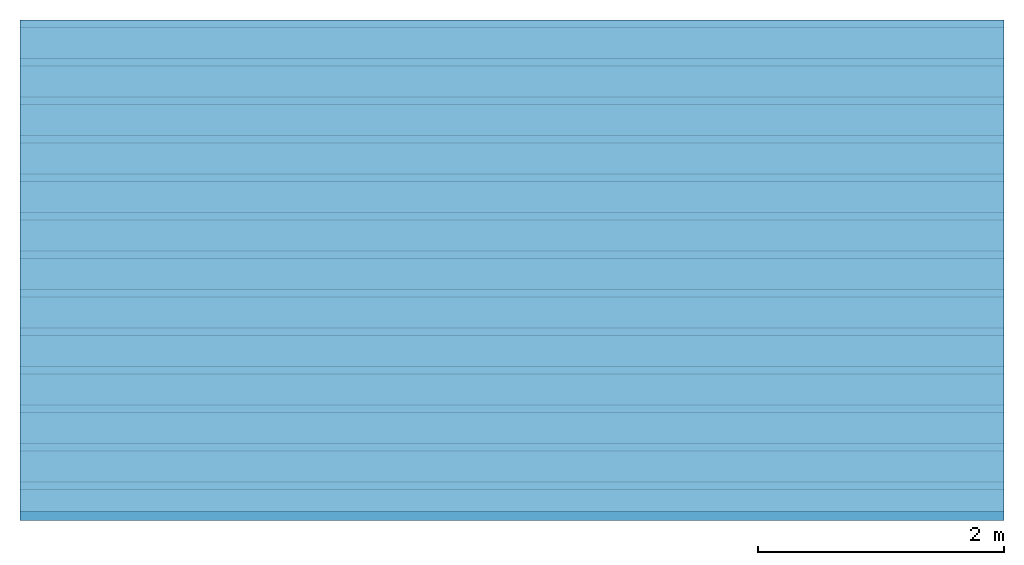
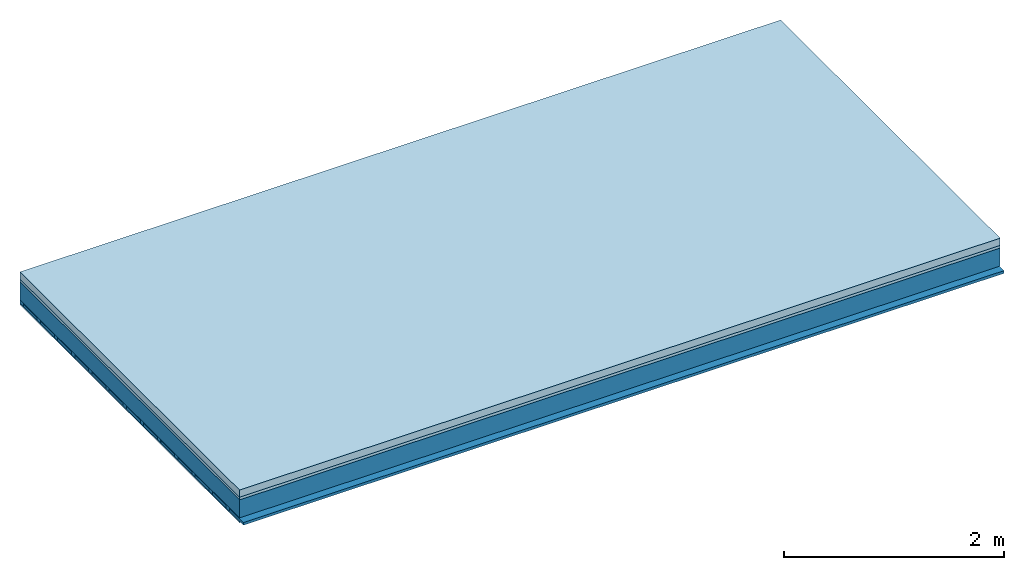
# One storey: 3 members, 3 plates, 1 element without a shape of its own.
"""IFC4 building model written with IfcOpenShell, lengths in metres."""

from ifc_helpers import new_model, si_unit, derived_unit, direction, frame, frame_2d, origin, origin_with_axes, place, context, project, spatial, rectangle, extrude, material, layer, layer_set, type_object, element, aggregate, save


model = new_model("IFC4")

# Units and contexts
plan_context = context("Plan", 3, precision=1e-05, world=origin(), true_north=direction((0.0, 1.0)))
model_context = context("Model", 3, precision=1e-05, world=origin(), true_north=direction((0.0, 1.0)))
ifc_project = project(units=[si_unit("LENGTHUNIT", "METRE"), derived_unit("SOUNDPRESSUREUNIT", [(si_unit("PRESSUREUNIT", "PASCAL", prefix="MICRO"), 0)]), si_unit("ENERGYUNIT", "JOULE", prefix="MEGA"), si_unit("MASSUNIT", "GRAM", prefix="KILO"), derived_unit("THERMALTRANSMITTANCEUNIT", [(si_unit("POWERUNIT", "WATT"), 1), (si_unit("AREAUNIT", "SQUARE_METRE"), -1), (si_unit("THERMODYNAMICTEMPERATUREUNIT", "KELVIN"), -1)]), derived_unit("AREADENSITYUNIT", [(si_unit("MASSUNIT", "GRAM", prefix="KILO"), 1), (si_unit("AREAUNIT", "SQUARE_METRE"), -1)]), derived_unit("USERDEFINED", [(si_unit("ENERGYUNIT", "JOULE", prefix="MEGA"), 1), (si_unit("AREAUNIT", "SQUARE_METRE"), -1)])], contexts=[plan_context, model_context])

# Site, building, storey
site = spatial("IfcSite", under=ifc_project)
building_placement = place(None, origin())
building = spatial("IfcBuilding", under=site, at=building_placement)
storey_placement = place(building_placement, origin())
storey = spatial("IfcBuildingStorey", under=building, at=storey_placement)

# Slab, members, plates
ifc_material_1 = material(Name="Cement screed", Category="04.006")
ifc_layer_1 = layer(ifc_material_1, 0.08, Name="On-material")
ifc_material_2 = material()
ifc_layer_2 = layer(ifc_material_2, 0.03, Name="Impact sound insulation")
ifc_layer_3 = layer(None, 0.2, Name="Supporting structure")
ifc_material_3 = material(Name="of the art")
ifc_layer_4 = layer(ifc_material_3, 0.0, Name="Bond")
ifc_layer_5 = layer(None, 0.04, Name="Battens / profiles")
ifc_material_4 = material(Category="03.007")
ifc_layer_6 = layer(ifc_material_4, 0.015, Name="Ceiling covering 1st layer")
ifc_material_5 = material(Name="Glued joints")
ifc_layer_7 = layer(ifc_material_5, 0.0, Name="Surface / treatment")
ifc_layer_set = layer_set([ifc_layer_1, ifc_layer_2, ifc_layer_3, ifc_layer_4, ifc_layer_5, ifc_layer_6, ifc_layer_7])
slab_type = type_object("IfcSlabType", Name="A0847", PredefinedType="NOTDEFINED", material=ifc_layer_set)
slab_placement = place(None, frame((0.0, 0.0, 0.0), z_axis=(0.0, 0.0, -1.0), x_axis=(1.0, 0.0, 0.0)))
slab = element("IfcSlab", 1, at=slab_placement, inside=storey, type_object=slab_type, material=ifc_layer_set, Name="Slab #1")
ifc_material_6 = material()
member_1_placement = place(slab_placement, origin())
member_1 = element("IfcMember", 2, at=member_1_placement, material=ifc_material_6, Name="Supporting structure", context=plan_context, shape_type="SweptSolid", body=[
    extrude(rectangle(XDim=1.0, YDim=0.2, at=frame_2d((0.5, 0.1), x_axis=(1.0, 0.0))), frame((0.0, 4.0, 0.11), z_axis=(0.0, -1.0, 0.0), x_axis=(1.0, 0.0, 0.0)), (0.0, 0.0, 1.0), 4.0),
    extrude(rectangle(XDim=1.0, YDim=0.2, at=frame_2d((0.5, 0.1), x_axis=(1.0, 0.0))), frame((1.0, 4.0, 0.11), z_axis=(0.0, -1.0, 0.0), x_axis=(1.0, 0.0, 0.0)), (0.0, 0.0, 1.0), 4.0),
    extrude(rectangle(XDim=1.0, YDim=0.2, at=frame_2d((0.5, 0.1), x_axis=(1.0, 0.0))), frame((2.0, 4.0, 0.11), z_axis=(0.0, -1.0, 0.0), x_axis=(1.0, 0.0, 0.0)), (0.0, 0.0, 1.0), 4.0),
    extrude(rectangle(XDim=1.0, YDim=0.2, at=frame_2d((0.5, 0.1), x_axis=(1.0, 0.0))), frame((3.0, 4.0, 0.11), z_axis=(0.0, -1.0, 0.0), x_axis=(1.0, 0.0, 0.0)), (0.0, 0.0, 1.0), 4.0),
    extrude(rectangle(XDim=1.0, YDim=0.2, at=frame_2d((0.5, 0.1), x_axis=(1.0, 0.0))), frame((4.0, 4.0, 0.11), z_axis=(0.0, -1.0, 0.0), x_axis=(1.0, 0.0, 0.0)), (0.0, 0.0, 1.0), 4.0),
    extrude(rectangle(XDim=1.0, YDim=0.2, at=frame_2d((0.5, 0.1), x_axis=(1.0, 0.0))), frame((5.0, 4.0, 0.11), z_axis=(0.0, -1.0, 0.0), x_axis=(1.0, 0.0, 0.0)), (0.0, 0.0, 1.0), 4.0),
    extrude(rectangle(XDim=1.0, YDim=0.2, at=frame_2d((0.5, 0.1), x_axis=(1.0, 0.0))), frame((6.0, 4.0, 0.11), z_axis=(0.0, -1.0, 0.0), x_axis=(1.0, 0.0, 0.0)), (0.0, 0.0, 1.0), 4.0),
    extrude(rectangle(XDim=1.0, YDim=0.2, at=frame_2d((0.5, 0.1), x_axis=(1.0, 0.0))), frame((7.0, 4.0, 0.11), z_axis=(0.0, -1.0, 0.0), x_axis=(1.0, 0.0, 0.0)), (0.0, 0.0, 1.0), 4.0),
])
ifc_material_7 = material()
member_2_placement = place(slab_placement, origin())
member_2 = element("IfcMember", 3, at=member_2_placement, material=ifc_material_7, Name="Battens / profiles", context=plan_context, shape_type="SweptSolid", body=[
    extrude(rectangle(XDim=0.06, YDim=0.04, at=frame_2d((0.03, 0.02), x_axis=(1.0, 0.0))), frame((0.0, 0.0, 0.31), z_axis=(1.0, 0.0, 0.0), x_axis=(0.0, 1.0, 0.0)), (0.0, 0.0, 1.0), 8.0),
    extrude(rectangle(XDim=0.06, YDim=0.04, at=frame_2d((0.03, 0.02), x_axis=(1.0, 0.0))), frame((0.0, 0.313, 0.31), z_axis=(1.0, 0.0, 0.0), x_axis=(0.0, 1.0, 0.0)), (0.0, 0.0, 1.0), 8.0),
    extrude(rectangle(XDim=0.06, YDim=0.04, at=frame_2d((0.03, 0.02), x_axis=(1.0, 0.0))), frame((0.0, 0.626, 0.31), z_axis=(1.0, 0.0, 0.0), x_axis=(0.0, 1.0, 0.0)), (0.0, 0.0, 1.0), 8.0),
    extrude(rectangle(XDim=0.06, YDim=0.04, at=frame_2d((0.03, 0.02), x_axis=(1.0, 0.0))), frame((0.0, 0.939, 0.31), z_axis=(1.0, 0.0, 0.0), x_axis=(0.0, 1.0, 0.0)), (0.0, 0.0, 1.0), 8.0),
    extrude(rectangle(XDim=0.06, YDim=0.04, at=frame_2d((0.03, 0.02), x_axis=(1.0, 0.0))), frame((0.0, 1.252, 0.31), z_axis=(1.0, 0.0, 0.0), x_axis=(0.0, 1.0, 0.0)), (0.0, 0.0, 1.0), 8.0),
    extrude(rectangle(XDim=0.06, YDim=0.04, at=frame_2d((0.03, 0.02), x_axis=(1.0, 0.0))), frame((0.0, 1.565, 0.31), z_axis=(1.0, 0.0, 0.0), x_axis=(0.0, 1.0, 0.0)), (0.0, 0.0, 1.0), 8.0),
    extrude(rectangle(XDim=0.06, YDim=0.04, at=frame_2d((0.03, 0.02), x_axis=(1.0, 0.0))), frame((0.0, 1.878, 0.31), z_axis=(1.0, 0.0, 0.0), x_axis=(0.0, 1.0, 0.0)), (0.0, 0.0, 1.0), 8.0),
    extrude(rectangle(XDim=0.06, YDim=0.04, at=frame_2d((0.03, 0.02), x_axis=(1.0, 0.0))), frame((0.0, 2.191, 0.31), z_axis=(1.0, 0.0, 0.0), x_axis=(0.0, 1.0, 0.0)), (0.0, 0.0, 1.0), 8.0),
    extrude(rectangle(XDim=0.06, YDim=0.04, at=frame_2d((0.03, 0.02), x_axis=(1.0, 0.0))), frame((0.0, 2.504, 0.31), z_axis=(1.0, 0.0, 0.0), x_axis=(0.0, 1.0, 0.0)), (0.0, 0.0, 1.0), 8.0),
    extrude(rectangle(XDim=0.06, YDim=0.04, at=frame_2d((0.03, 0.02), x_axis=(1.0, 0.0))), frame((0.0, 2.817, 0.31), z_axis=(1.0, 0.0, 0.0), x_axis=(0.0, 1.0, 0.0)), (0.0, 0.0, 1.0), 8.0),
    extrude(rectangle(XDim=0.06, YDim=0.04, at=frame_2d((0.03, 0.02), x_axis=(1.0, 0.0))), frame((0.0, 3.13, 0.31), z_axis=(1.0, 0.0, 0.0), x_axis=(0.0, 1.0, 0.0)), (0.0, 0.0, 1.0), 8.0),
    extrude(rectangle(XDim=0.06, YDim=0.04, at=frame_2d((0.03, 0.02), x_axis=(1.0, 0.0))), frame((0.0, 3.443, 0.31), z_axis=(1.0, 0.0, 0.0), x_axis=(0.0, 1.0, 0.0)), (0.0, 0.0, 1.0), 8.0),
    extrude(rectangle(XDim=0.06, YDim=0.04, at=frame_2d((0.03, 0.02), x_axis=(1.0, 0.0))), frame((0.0, 3.756, 0.31), z_axis=(1.0, 0.0, 0.0), x_axis=(0.0, 1.0, 0.0)), (0.0, 0.0, 1.0), 8.0),
])
ifc_material_8 = material()
member_3_placement = place(slab_placement, origin())
member_3 = element("IfcMember", 4, at=member_3_placement, material=ifc_material_8, Name="Cavity", context=plan_context, shape_type="SweptSolid", body=[
    extrude(rectangle(XDim=0.253, YDim=0.03, at=frame_2d((0.1265, 0.015), x_axis=(1.0, 0.0))), frame((0.0, 0.06, 0.32), z_axis=(1.0, 0.0, 0.0), x_axis=(0.0, 1.0, 0.0)), (0.0, 0.0, 1.0), 8.0),
    extrude(rectangle(XDim=0.253, YDim=0.03, at=frame_2d((0.1265, 0.015), x_axis=(1.0, 0.0))), frame((0.0, 0.373, 0.32), z_axis=(1.0, 0.0, 0.0), x_axis=(0.0, 1.0, 0.0)), (0.0, 0.0, 1.0), 8.0),
    extrude(rectangle(XDim=0.253, YDim=0.03, at=frame_2d((0.1265, 0.015), x_axis=(1.0, 0.0))), frame((0.0, 0.686, 0.32), z_axis=(1.0, 0.0, 0.0), x_axis=(0.0, 1.0, 0.0)), (0.0, 0.0, 1.0), 8.0),
    extrude(rectangle(XDim=0.253, YDim=0.03, at=frame_2d((0.1265, 0.015), x_axis=(1.0, 0.0))), frame((0.0, 0.999, 0.32), z_axis=(1.0, 0.0, 0.0), x_axis=(0.0, 1.0, 0.0)), (0.0, 0.0, 1.0), 8.0),
    extrude(rectangle(XDim=0.253, YDim=0.03, at=frame_2d((0.1265, 0.015), x_axis=(1.0, 0.0))), frame((0.0, 1.312, 0.32), z_axis=(1.0, 0.0, 0.0), x_axis=(0.0, 1.0, 0.0)), (0.0, 0.0, 1.0), 8.0),
    extrude(rectangle(XDim=0.253, YDim=0.03, at=frame_2d((0.1265, 0.015), x_axis=(1.0, 0.0))), frame((0.0, 1.625, 0.32), z_axis=(1.0, 0.0, 0.0), x_axis=(0.0, 1.0, 0.0)), (0.0, 0.0, 1.0), 8.0),
    extrude(rectangle(XDim=0.253, YDim=0.03, at=frame_2d((0.1265, 0.015), x_axis=(1.0, 0.0))), frame((0.0, 1.938, 0.32), z_axis=(1.0, 0.0, 0.0), x_axis=(0.0, 1.0, 0.0)), (0.0, 0.0, 1.0), 8.0),
    extrude(rectangle(XDim=0.253, YDim=0.03, at=frame_2d((0.1265, 0.015), x_axis=(1.0, 0.0))), frame((0.0, 2.251, 0.32), z_axis=(1.0, 0.0, 0.0), x_axis=(0.0, 1.0, 0.0)), (0.0, 0.0, 1.0), 8.0),
    extrude(rectangle(XDim=0.253, YDim=0.03, at=frame_2d((0.1265, 0.015), x_axis=(1.0, 0.0))), frame((0.0, 2.564, 0.32), z_axis=(1.0, 0.0, 0.0), x_axis=(0.0, 1.0, 0.0)), (0.0, 0.0, 1.0), 8.0),
    extrude(rectangle(XDim=0.253, YDim=0.03, at=frame_2d((0.1265, 0.015), x_axis=(1.0, 0.0))), frame((0.0, 2.877, 0.32), z_axis=(1.0, 0.0, 0.0), x_axis=(0.0, 1.0, 0.0)), (0.0, 0.0, 1.0), 8.0),
    extrude(rectangle(XDim=0.253, YDim=0.03, at=frame_2d((0.1265, 0.015), x_axis=(1.0, 0.0))), frame((0.0, 3.19, 0.32), z_axis=(1.0, 0.0, 0.0), x_axis=(0.0, 1.0, 0.0)), (0.0, 0.0, 1.0), 8.0),
    extrude(rectangle(XDim=0.253, YDim=0.03, at=frame_2d((0.1265, 0.015), x_axis=(1.0, 0.0))), frame((0.0, 3.503, 0.32), z_axis=(1.0, 0.0, 0.0), x_axis=(0.0, 1.0, 0.0)), (0.0, 0.0, 1.0), 8.0),
    extrude(rectangle(XDim=0.253, YDim=0.03, at=frame_2d((0.1265, 0.015), x_axis=(1.0, 0.0))), frame((0.0, 3.816, 0.32), z_axis=(1.0, 0.0, 0.0), x_axis=(0.0, 1.0, 0.0)), (0.0, 0.0, 1.0), 8.0),
])
plate_1_placement = place(slab_placement, origin())
plate_1 = element("IfcPlate", 5, at=plate_1_placement, material=ifc_material_1, Name="On-material", context=plan_context, shape_type="SweptSolid", body=[
    extrude(rectangle(XDim=8.0, YDim=4.0, at=frame_2d((4.0, 2.0), x_axis=(1.0, 0.0))), origin_with_axes(), (0.0, 0.0, 1.0), 0.08),
])
plate_2_placement = place(slab_placement, origin())
plate_2 = element("IfcPlate", 6, at=plate_2_placement, material=ifc_material_2, Name="Impact sound insulation", context=plan_context, shape_type="SweptSolid", body=[
    extrude(rectangle(XDim=8.0, YDim=4.0, at=frame_2d((4.0, 2.0), x_axis=(1.0, 0.0))), frame((0.0, 0.0, 0.08), z_axis=(0.0, 0.0, 1.0), x_axis=(1.0, 0.0, 0.0)), (0.0, 0.0, 1.0), 0.03),
])
plate_3_placement = place(slab_placement, origin())
plate_3 = element("IfcPlate", 7, at=plate_3_placement, material=ifc_material_4, Name="Ceiling covering 1st layer", context=plan_context, shape_type="SweptSolid", body=[
    extrude(rectangle(XDim=8.0, YDim=4.0, at=frame_2d((4.0, 2.0), x_axis=(1.0, 0.0))), frame((0.0, 0.0, 0.35), z_axis=(0.0, 0.0, 1.0), x_axis=(1.0, 0.0, 0.0)), (0.0, 0.0, 1.0), 0.015),
])
aggregate(slab, [plate_1, plate_2, member_1, member_2, member_3, plate_3])

save(model, "model.ifc")
